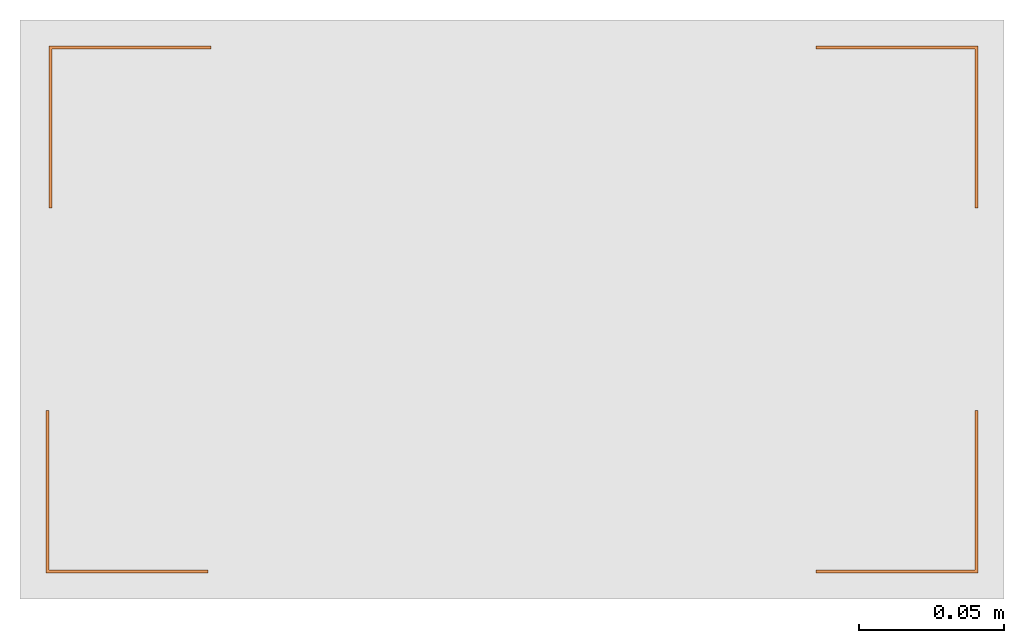
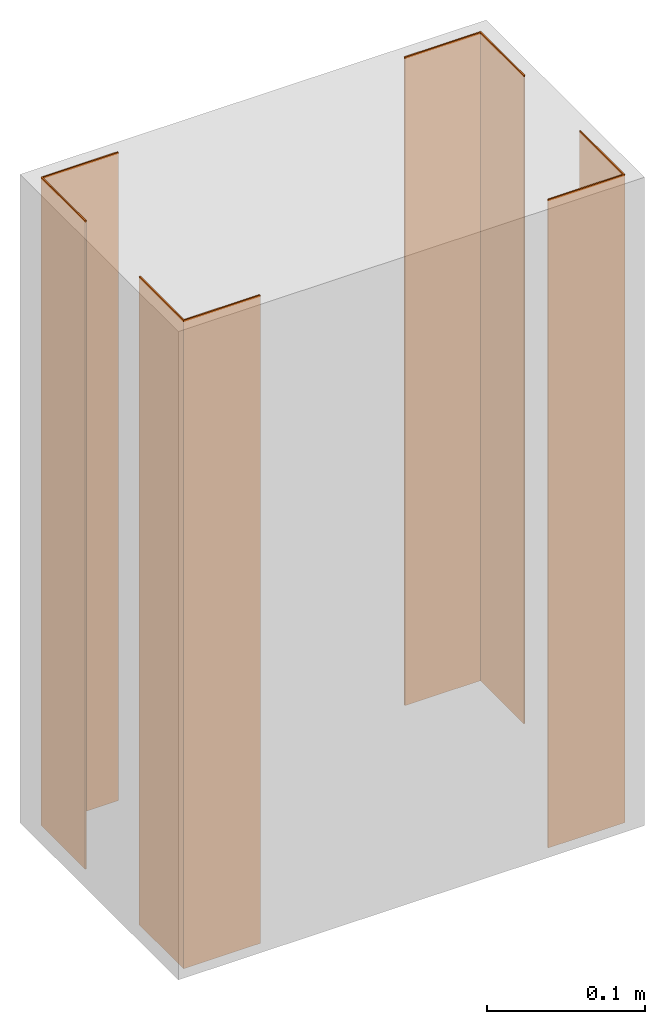
# One storey, part 2 of 2: 4 proxies.
"""IFC2X3 building model written with IfcOpenShell, lengths in millimetres."""

from ifc_helpers import new_model, entity, si_unit, converted_unit, derived_unit, direction, frame, origin, place, context, subcontext, project, spatial, polyline, outline, extrude, source, transform, mapped, type_object, type_shapes, element, save


model = new_model("IFC2X3")

# Units and contexts
model_context = context("Model", 3, precision=0.01, world=origin(), true_north=direction((6.12303176911189e-17, 1.0)))
context_of_model = context(None, 3, precision=0.01, world=origin(), true_north=direction((6.12303176911189e-17, 1.0)))
body_context = subcontext(model_context, "Body", "Model", "MODEL_VIEW")
ifc_project = project(units=[si_unit("LENGTHUNIT", "METRE", prefix="MILLI"), si_unit("AREAUNIT", "SQUARE_METRE"), si_unit("VOLUMEUNIT", "CUBIC_METRE"), converted_unit("PLANEANGLEUNIT", "DEGREE", entity("IfcRatioMeasure", 0.0174532925199433), si_unit("PLANEANGLEUNIT", "RADIAN"), dimensions=[0, 0, 0, 0, 0, 0, 0]), si_unit("MASSUNIT", "GRAM", prefix="KILO"), si_unit("TIMEUNIT", "SECOND"), si_unit("FREQUENCYUNIT", "HERTZ"), si_unit("THERMODYNAMICTEMPERATUREUNIT", "DEGREE_CELSIUS"), derived_unit("THERMALTRANSMITTANCEUNIT", [(si_unit("MASSUNIT", "GRAM", prefix="KILO"), 1), (si_unit("THERMODYNAMICTEMPERATUREUNIT", "KELVIN"), -1), (si_unit("TIMEUNIT", "SECOND"), -3)]), derived_unit("VOLUMETRICFLOWRATEUNIT", [(si_unit("LENGTHUNIT", "METRE"), 3), (si_unit("TIMEUNIT", "SECOND"), -1)]), si_unit("ELECTRICCURRENTUNIT", "AMPERE"), si_unit("ELECTRICVOLTAGEUNIT", "VOLT"), si_unit("POWERUNIT", "WATT"), si_unit("FORCEUNIT", "NEWTON", prefix="KILO"), si_unit("ILLUMINANCEUNIT", "LUX"), si_unit("LUMINOUSFLUXUNIT", "LUMEN"), si_unit("LUMINOUSINTENSITYUNIT", "CANDELA"), si_unit("PRESSUREUNIT", "PASCAL")], contexts=[model_context, context_of_model])

# Site, building, storey
site_placement = place(None, origin())
site = spatial("IfcSite", under=ifc_project, at=site_placement, CompositionType="ELEMENT")
building_placement = place(site_placement, origin())
building = spatial("IfcBuilding", under=site, at=building_placement, CompositionType="ELEMENT")
storey_placement = place(building_placement, origin())
storey = spatial("IfcBuildingStorey", under=building, at=storey_placement, CompositionType="ELEMENT", Elevation=0.0)

# Proxies
building_element_proxy_type_1 = type_object("IfcBuildingElementProxyType", PredefinedType="NOTDEFINED")
shared_shape_1 = source(origin(), body_context, "Body", "SweptSolid", [
    extrude(outline(polyline([(-19.0, -19.0), (37.0, -19.0), (37.0, -18.0), (-18.0, -18.0), (-18.0, 37.0), (-19.0, 37.0), (-19.0, -19.0)])), frame((97.0, 72.0, 0.0), z_axis=(0.0, 0.0, 1.0), x_axis=(-1.0, 0.0, 0.0)), (0.0, 0.0, 1.0), 500.0),
])
type_shapes(building_element_proxy_type_1, [shared_shape_1])
proxy_1_placement = place(storey_placement, frame((-6518.6486027535, 5158.37431996578, 0.0), z_axis=(0.0, 0.0, 1.0), x_axis=(-1.0, 0.0, 0.0)))
element("IfcBuildingElementProxy", 1, at=proxy_1_placement, inside=storey, type_object=building_element_proxy_type_1, context=body_context, shape_type="MappedRepresentation", body=[
    mapped(shared_shape_1, transform((0.0, 0.0, 0.0), scale=1.0)),
])
proxy_2_placement = place(storey_placement, frame((-6428.64860275349, 5158.37431996578, 0.0)))
element("IfcBuildingElementProxy", 2, at=proxy_2_placement, inside=storey, type_object=building_element_proxy_type_1, context=body_context, shape_type="MappedRepresentation", body=[
    mapped(shared_shape_1, transform((0.0, 0.0, 0.0), scale=1.0)),
])
building_element_proxy_type_2 = type_object("IfcBuildingElementProxyType", PredefinedType="NOTDEFINED")
shared_shape_2 = source(origin(), body_context, "Body", "SweptSolid", [
    extrude(outline(polyline([(-19.0, -19.0), (37.0, -19.0), (37.0, -18.0), (-18.0, -18.0), (-18.0, 37.0), (-19.0, 37.0), (-19.0, -19.0)])), frame((153.0, 72.0, 0.0), z_axis=(0.0, 0.0, 1.0), x_axis=(0.0, -1.0, 0.0)), (0.0, 0.0, 1.0), 500.0),
])
type_shapes(building_element_proxy_type_2, [shared_shape_2])
proxy_3_placement = place(storey_placement, frame((-6767.64860275349, 5158.37431996578, 0.0)))
element("IfcBuildingElementProxy", 3, at=proxy_3_placement, inside=storey, type_object=building_element_proxy_type_2, context=body_context, shape_type="MappedRepresentation", body=[
    mapped(shared_shape_2, transform((0.0, 0.0, 0.0), scale=1.0)),
])
proxy_4_placement = place(storey_placement, frame((-6178.6486027535, 5158.37431996578, 0.0), z_axis=(0.0, 0.0, 1.0), x_axis=(-1.0, 0.0, 0.0)))
element("IfcBuildingElementProxy", 4, at=proxy_4_placement, inside=storey, type_object=building_element_proxy_type_2, context=body_context, shape_type="MappedRepresentation", body=[
    mapped(shared_shape_2, transform((0.0, 0.0, 0.0), scale=1.0)),
])

save(model, "model.ifc")
